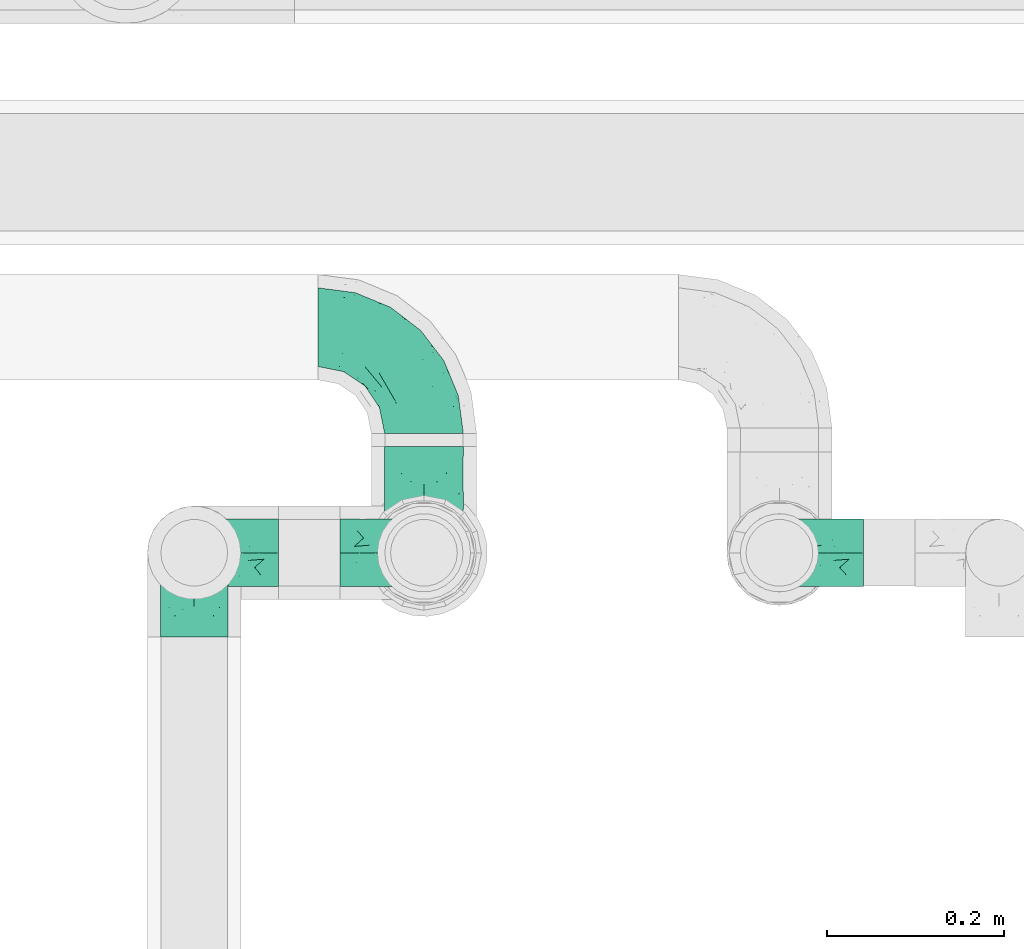
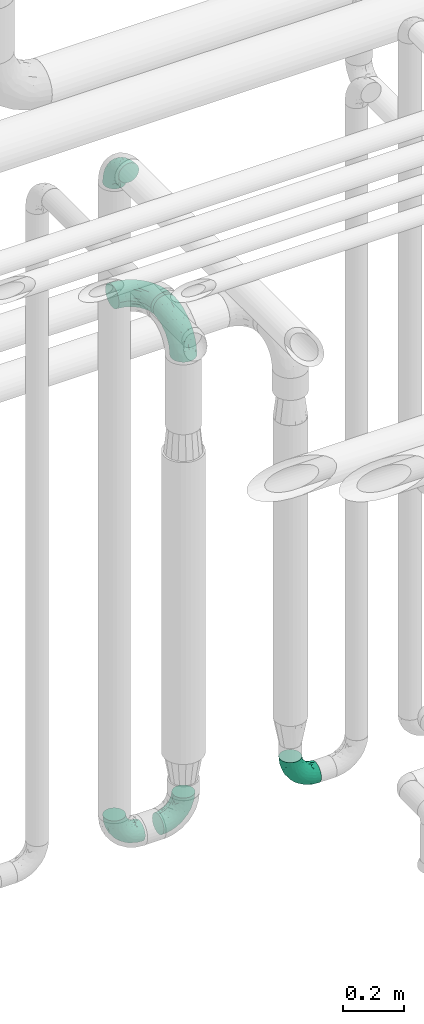
# One storey, part 711 of 827: 6 flow fittings.
"""IFC2X3 building model written with IfcOpenShell, lengths in millimetres."""

from ifc_helpers import new_model, entity, si_unit, converted_unit, derived_unit, direction, frame, origin, place, context, subcontext, project, spatial, faceted_brep, source, transform, mapped, material, type_object, type_shapes, element, save


model = new_model("IFC2X3")

# Units and contexts
model_context = context("Model", 3, precision=0.01, world=origin(), true_north=direction((6.12303176911189e-17, 1.0)))
body_context = subcontext(model_context, "Body", "Model", "MODEL_VIEW")
ifc_project = project(units=[si_unit("LENGTHUNIT", "METRE", prefix="MILLI"), si_unit("AREAUNIT", "SQUARE_METRE"), si_unit("VOLUMEUNIT", "CUBIC_METRE"), converted_unit("PLANEANGLEUNIT", "DEGREE", entity("IfcRatioMeasure", 0.0174532925199433), si_unit("PLANEANGLEUNIT", "RADIAN"), dimensions=[0, 0, 0, 0, 0, 0, 0]), si_unit("MASSUNIT", "GRAM", prefix="KILO"), derived_unit("MASSDENSITYUNIT", [(si_unit("MASSUNIT", "GRAM", prefix="KILO"), 1), (si_unit("LENGTHUNIT", "METRE"), -3)]), derived_unit("MOMENTOFINERTIAUNIT", [(si_unit("LENGTHUNIT", "METRE"), 4)]), si_unit("TIMEUNIT", "SECOND"), si_unit("FREQUENCYUNIT", "HERTZ"), si_unit("THERMODYNAMICTEMPERATUREUNIT", "DEGREE_CELSIUS"), derived_unit("THERMALTRANSMITTANCEUNIT", [(si_unit("MASSUNIT", "GRAM", prefix="KILO"), 1), (si_unit("THERMODYNAMICTEMPERATUREUNIT", "KELVIN"), -1), (si_unit("TIMEUNIT", "SECOND"), -3)]), derived_unit("VOLUMETRICFLOWRATEUNIT", [(si_unit("LENGTHUNIT", "METRE"), 3), (si_unit("TIMEUNIT", "SECOND"), -1)]), derived_unit("MASSFLOWRATEUNIT", [(si_unit("MASSUNIT", "GRAM", prefix="KILO"), 1), (si_unit("TIMEUNIT", "SECOND"), -1)]), derived_unit("ROTATIONALFREQUENCYUNIT", [(si_unit("TIMEUNIT", "SECOND"), -1)]), si_unit("ELECTRICCURRENTUNIT", "AMPERE"), si_unit("ELECTRICVOLTAGEUNIT", "VOLT"), si_unit("POWERUNIT", "WATT"), si_unit("FORCEUNIT", "NEWTON", prefix="KILO"), si_unit("ILLUMINANCEUNIT", "LUX"), si_unit("LUMINOUSFLUXUNIT", "LUMEN"), si_unit("LUMINOUSINTENSITYUNIT", "CANDELA"), derived_unit("USERDEFINED", [(si_unit("MASSUNIT", "GRAM", prefix="KILO"), -1), (si_unit("LENGTHUNIT", "METRE"), -2), (si_unit("TIMEUNIT", "SECOND"), 3), (si_unit("LUMINOUSFLUXUNIT", "LUMEN"), 1)]), derived_unit("LINEARVELOCITYUNIT", [(si_unit("LENGTHUNIT", "METRE"), 1), (si_unit("TIMEUNIT", "SECOND"), -1)]), si_unit("PRESSUREUNIT", "PASCAL"), derived_unit("USERDEFINED", [(si_unit("LENGTHUNIT", "METRE"), -2), (si_unit("MASSUNIT", "GRAM", prefix="KILO"), 1), (si_unit("TIMEUNIT", "SECOND"), -2)]), derived_unit("LINEARFORCEUNIT", [(si_unit("MASSUNIT", "GRAM", prefix="KILO"), 1), (si_unit("LENGTHUNIT", "METRE"), 1), (si_unit("TIMEUNIT", "SECOND"), -2), (si_unit("LENGTHUNIT", "METRE"), -1)]), derived_unit("PLANARFORCEUNIT", [(si_unit("MASSUNIT", "GRAM", prefix="KILO"), 1), (si_unit("LENGTHUNIT", "METRE"), 1), (si_unit("TIMEUNIT", "SECOND"), -2), (si_unit("LENGTHUNIT", "METRE"), -2)])], contexts=[model_context])

# Site, building, storey
site_placement = place(None, origin())
site = spatial("IfcSite", under=ifc_project, at=site_placement, CompositionType="ELEMENT")
building_placement = place(site_placement, origin())
building = spatial("IfcBuilding", under=site, at=building_placement, CompositionType="ELEMENT")
storey_placement = place(building_placement, frame((0.0, 0.0, 28200.0)))
storey = spatial("IfcBuildingStorey", under=building, at=storey_placement, Name="08", CompositionType="ELEMENT", Elevation=28200.0)

# Flow fittings
ifc_material = material()
pipe_fitting_type_1 = type_object("IfcPipeFittingType", Name="ADSK_2", PredefinedType="NOTDEFINED", material=ifc_material)
shared_shape_1 = source(origin(), body_context, "Body", "Brep", [
    faceted_brep([(-120.0, 22.25, -38.54), (-120.0, 11.52, -42.98), (-120.0, 0.0, -44.5), (-120.0, -11.52, -42.98), (-120.0, -22.25, -38.54), (-120.0, -31.47, -31.47), (-120.0, -38.54, -22.25), (-120.0, -42.98, -11.52), (-120.0, -44.5, 0.0), (-120.0, -42.98, 11.52), (-120.0, -38.54, 22.25), (-120.0, -31.47, 31.47), (-120.0, -22.25, 38.54), (-120.0, -11.52, 42.98), (-120.0, 0.0, 44.5), (-120.0, 11.52, 42.98), (-120.0, 22.25, 38.54), (-120.0, 31.47, 31.47), (-120.0, 38.54, 22.25), (-120.0, 42.98, 11.52), (-120.0, 44.5, 0.0), (-120.0, 42.98, -11.52), (-120.0, 38.54, -22.25), (-120.0, 31.47, -31.47), (0.0, 120.0, -44.5), (-11.52, 120.0, -42.98), (-22.25, 120.0, -38.54), (-31.47, 120.0, -31.47), (-38.54, 120.0, -22.25), (-42.98, 120.0, -11.52), (-44.5, 120.0, 0.0), (-42.98, 120.0, 11.52), (-38.54, 120.0, 22.25), (-31.47, 120.0, 31.47), (-22.25, 120.0, 38.54), (-11.52, 120.0, 42.98), (0.0, 120.0, 44.5), (11.52, 120.0, 42.98), (22.25, 120.0, 38.54), (31.47, 120.0, 31.47), (38.54, 120.0, 22.25), (42.98, 120.0, 11.52), (44.5, 120.0, 0.0), (42.98, 120.0, -11.52), (38.54, 120.0, -22.25), (31.47, 120.0, -31.47), (22.25, 120.0, -38.54), (11.52, 120.0, -42.98), (-20.51, 85.66, 41.98), (-29.31, 93.55, 36.45), (-98.0, -41.6, 0.0), (-80.92, -37.22, 14.68), (-66.68, -9.63, 39.67), (-84.59, -24.55, 33.9), (-50.35, -12.87, 32.85), (-77.42, -38.89, 0.0), (-22.01, -9.62, 13.21), (-37.75, -22.46, 0.0), (-20.72, -9.39, 0.0), (-89.18, -33.47, 25.4), (12.87, 50.35, 32.85), (24.55, 84.59, 33.9), (9.63, 66.68, 39.67), (-49.55, -27.06, 11.21), (-28.67, -9.99, 21.67), (-52.01, -22.41, 23.47), (-95.53, -16.28, 40.49), (-86.01, -3.42, 43.77), (22.41, 52.01, 23.47), (9.05, 21.37, 13.44), (26.5, 49.37, 12.73), (33.47, 89.18, 25.4), (37.22, 80.92, 14.68), (16.28, 95.53, 40.49), (3.42, 86.01, 43.77), (-7.84, 52.6, 43.16), (-84.39, 31.88, 36.84), (-30.52, 34.28, 44.33), (-21.99, 28.55, 42.22), (-93.56, 38.23, 28.63), (-65.04, 31.74, 41.51), (-91.98, 19.0, 41.83), (-34.03, 70.24, 39.41), (-96.36, 44.0, 18.64), (-98.49, 46.74, 8.65), (-76.5, 56.97, 9.76), (-4.96, 4.47, 11.32), (-7.16, 6.18, 18.93), (-56.62, 75.93, 12.18), (-66.61, 66.61, 0.0), (-92.12, 7.25, 44.33), (-7.23, 92.66, 44.32), (30.68, 57.59, 0.0), (-44.45, 94.8, 18.75), (-36.39, 101.98, 28.14), (-46.83, 97.45, 9.69), (-38.03, 47.61, 43.21), (-24.7, 65.7, 43.29), (41.6, 98.0, 0.0), (-54.11, 72.8, 21.53), (-47.95, 9.75, 42.93), (-18.65, 18.65, 37.89), (-91.11, 50.25, 0.0), (-50.25, 91.11, 0.0), (-57.59, -30.68, 0.0), (-44.16, 67.2, 34.92), (-55.15, 62.16, 29.74), (-68.1, 47.21, 32.31), (-51.09, 51.09, 38.36), (-16.69, 62.62, 44.46), (-58.26, 18.84, 44.48), (-71.55, 55.71, 20.49), (-43.13, 80.04, 29.45), (-37.23, 0.88, 36.78), (-18.15, 10.22, 33.09), (5.51, 28.08, 26.74), (-3.68, 3.68, 0.0), (9.39, 20.72, 0.0), (-2.58, 27.98, 33.59), (-2.38, 41.22, 38.93), (-16.09, 4.55, 27.06), (38.89, 77.42, 0.0), (22.46, 37.75, 0.0), (-92.66, 7.23, -44.32), (-22.01, -9.62, -13.21), (-49.81, -26.66, -12.91), (-28.67, -9.99, -21.67), (-62.62, 16.69, -44.46), (-65.04, 31.74, -41.51), (-38.89, 47.26, -43.11), (-56.62, 75.93, -12.18), (-93.56, 38.23, -28.63), (-84.39, 31.88, -36.84), (16.28, 95.53, -40.49), (3.42, 86.01, -43.77), (-98.49, 46.74, -8.65), (-44.45, 94.8, -18.75), (-54.11, 72.8, -21.53), (-76.5, 56.97, -9.76), (24.55, 84.59, -33.9), (9.63, 66.68, -39.67), (-96.36, 44.0, -18.64), (-29.4, 93.16, -36.47), (-91.98, 19.0, -41.83), (-80.92, -37.22, -14.68), (-52.6, 7.84, -43.16), (-86.01, -3.42, -43.77), (-89.18, -33.47, -25.4), (-52.01, -22.41, -23.47), (-50.35, -12.87, -32.85), (-84.59, -24.55, -33.9), (-66.68, -9.63, -39.67), (-95.53, -16.28, -40.49), (-68.1, 47.21, -32.31), (-35.81, 11.1, -40.85), (-19.61, 28.53, -41.59), (-18.65, 18.65, -37.89), (-4.97, 4.47, -11.34), (9.05, 21.37, -13.44), (-34.28, 30.52, -44.33), (-9.75, 47.95, -42.93), (-2.58, 27.98, -33.59), (-18.15, 10.22, -33.09), (-46.83, 97.45, -9.69), (12.87, 50.35, -32.85), (26.8, 49.13, -11.4), (-7.34, 92.03, -44.33), (-21.02, 83.86, -42.03), (-44.6, 66.82, -34.8), (-55.46, 62.18, -29.47), (37.22, 80.92, -14.68), (33.47, 89.18, -25.4), (-34.39, 70.11, -39.28), (-25.04, 64.41, -43.37), (-18.84, 58.26, -44.48), (22.41, 52.01, -23.47), (-36.39, 101.98, -28.14), (-51.09, 51.09, -38.36), (-43.13, 80.04, -29.45), (-71.55, 55.71, -20.49), (-7.15, 6.2, -18.94), (5.51, 28.08, -26.74), (-37.23, 0.88, -36.78), (-2.38, 41.22, -38.93), (-16.09, 4.55, -27.06)], [[[0, 1, 2, 3, 4, 5, 6, 7, 8, 9, 10, 11, 12, 13, 14, 15, 16, 17, 18, 19, 20, 21, 22, 23]], [[24, 25, 26, 27, 28, 29, 30, 31, 32, 33, 34, 35, 36, 37, 38, 39, 40, 41, 42, 43, 44, 45, 46, 47]], [[48, 34, 49]], [[50, 51, 9]], [[52, 53, 54]], [[9, 51, 10]], [[55, 51, 50]], [[56, 57, 58]], [[51, 59, 10]], [[60, 61, 62]], [[63, 64, 65]], [[13, 12, 66]], [[67, 14, 13]], [[68, 69, 70]], [[71, 68, 72]], [[38, 73, 61]], [[74, 75, 62]], [[17, 16, 76]], [[77, 78, 75]], [[79, 18, 17]], [[80, 76, 81]], [[35, 34, 48]], [[49, 82, 48]], [[18, 83, 19]], [[16, 81, 76]], [[20, 19, 84]], [[85, 84, 83]], [[56, 86, 87]], [[85, 88, 89]], [[37, 36, 74]], [[90, 14, 67]], [[79, 17, 76]], [[63, 65, 51]], [[13, 66, 67]], [[61, 39, 38]], [[91, 74, 36]], [[70, 92, 72]], [[93, 94, 32]], [[95, 88, 93]], [[62, 73, 74]], [[82, 96, 97]], [[40, 72, 41]], [[72, 68, 70]], [[71, 72, 40]], [[34, 33, 49]], [[72, 98, 41]], [[99, 93, 88]], [[71, 39, 61]], [[78, 100, 101]], [[85, 89, 102]], [[53, 52, 66]], [[103, 95, 30]], [[12, 11, 53]], [[103, 89, 88]], [[104, 57, 63]], [[91, 48, 97]], [[93, 32, 31]], [[33, 32, 94]], [[16, 15, 81]], [[105, 106, 107]], [[76, 107, 79]], [[35, 91, 36]], [[80, 96, 108]], [[31, 95, 93]], [[65, 53, 59]], [[73, 38, 37]], [[75, 74, 109]], [[61, 60, 68]], [[11, 10, 59]], [[54, 53, 65]], [[100, 67, 52]], [[110, 81, 90]], [[15, 14, 90]], [[76, 80, 108]], [[107, 76, 108]], [[83, 79, 111]], [[94, 49, 33]], [[82, 105, 108]], [[84, 85, 102]], [[111, 88, 85]], [[99, 88, 111]], [[94, 93, 112]], [[48, 91, 35]], [[74, 91, 109]], [[69, 87, 86]], [[113, 54, 114]], [[64, 56, 87]], [[60, 115, 68]], [[116, 117, 86]], [[69, 68, 115]], [[79, 83, 18]], [[85, 83, 111]], [[81, 110, 80]], [[110, 77, 96]], [[110, 96, 80]], [[97, 96, 109]], [[107, 108, 105]], [[111, 79, 107]], [[77, 75, 109]], [[118, 119, 101]], [[96, 77, 109]], [[77, 110, 100]], [[67, 100, 110]], [[100, 52, 113]], [[60, 119, 118]], [[118, 120, 115]], [[64, 54, 65]], [[114, 120, 118]], [[118, 115, 60]], [[115, 120, 87]], [[74, 73, 37]], [[61, 73, 62]], [[53, 66, 12]], [[67, 66, 52]], [[110, 90, 67]], [[15, 90, 81]], [[105, 49, 112]], [[96, 82, 108]], [[119, 60, 62]], [[118, 101, 114]], [[62, 75, 119]], [[78, 119, 75]], [[49, 105, 82]], [[105, 112, 106]], [[99, 112, 93]], [[111, 107, 106]], [[113, 114, 101]], [[54, 120, 114]], [[100, 113, 101]], [[52, 54, 113]], [[20, 84, 102]], [[83, 84, 19]], [[111, 106, 99]], [[112, 99, 106]], [[100, 78, 77]], [[119, 78, 101]], [[39, 71, 40]], [[68, 71, 61]], [[65, 59, 51]], [[11, 59, 53]], [[30, 95, 31]], [[103, 88, 95]], [[9, 8, 50]], [[98, 72, 121]], [[98, 42, 41]], [[49, 94, 112]], [[56, 63, 57]], [[51, 55, 104]], [[92, 121, 72]], [[86, 58, 116]], [[54, 64, 120]], [[115, 87, 69]], [[120, 64, 87]], [[58, 86, 56]], [[86, 117, 69]], [[91, 97, 109]], [[122, 69, 117]], [[82, 97, 48]], [[63, 56, 64]], [[104, 63, 51]], [[69, 122, 70]], [[92, 70, 122]], [[123, 2, 1]], [[124, 125, 126]], [[127, 128, 129]], [[103, 130, 89]], [[23, 131, 132]], [[47, 133, 134]], [[102, 135, 20]], [[130, 136, 137]], [[102, 138, 135]], [[139, 140, 133]], [[22, 21, 141]], [[27, 26, 142]], [[46, 45, 139]], [[0, 143, 1]], [[6, 144, 7]], [[145, 146, 127]], [[144, 50, 7]], [[147, 148, 144]], [[144, 6, 147]], [[149, 150, 151]], [[4, 3, 152]], [[23, 22, 131]], [[132, 131, 153]], [[43, 42, 98]], [[125, 104, 144]], [[154, 155, 156]], [[146, 151, 152]], [[4, 150, 5]], [[123, 146, 2]], [[157, 158, 117]], [[130, 138, 89]], [[29, 28, 136]], [[159, 160, 155]], [[161, 162, 156]], [[89, 138, 102]], [[163, 30, 29]], [[164, 140, 139]], [[163, 136, 130]], [[23, 132, 0]], [[158, 165, 122]], [[25, 24, 166]], [[0, 132, 143]], [[4, 152, 150]], [[142, 26, 167]], [[3, 2, 146]], [[167, 26, 25]], [[133, 47, 46]], [[168, 153, 169]], [[146, 145, 151]], [[149, 126, 148]], [[44, 170, 171]], [[24, 47, 134]], [[170, 44, 43]], [[144, 148, 125]], [[170, 98, 121]], [[168, 142, 172]], [[129, 173, 174]], [[98, 170, 43]], [[147, 5, 150]], [[157, 58, 124]], [[92, 122, 165]], [[134, 166, 24]], [[175, 139, 171]], [[28, 27, 176]], [[29, 136, 163]], [[132, 128, 143]], [[45, 44, 171]], [[164, 139, 175]], [[160, 134, 140]], [[174, 173, 166]], [[141, 131, 22]], [[132, 153, 177]], [[128, 132, 177]], [[123, 143, 127]], [[172, 142, 167]], [[176, 142, 178]], [[130, 179, 138]], [[138, 179, 141]], [[176, 136, 28]], [[130, 137, 179]], [[174, 166, 134]], [[167, 25, 166]], [[143, 123, 1]], [[146, 123, 127]], [[150, 149, 148]], [[157, 124, 180]], [[181, 161, 164]], [[181, 158, 180]], [[124, 126, 180]], [[170, 165, 175]], [[141, 21, 135]], [[131, 141, 179]], [[131, 179, 153]], [[179, 137, 169]], [[129, 128, 177]], [[127, 143, 128]], [[129, 177, 172]], [[129, 174, 159]], [[159, 145, 127]], [[182, 154, 156]], [[129, 159, 127]], [[159, 174, 160]], [[134, 160, 174]], [[140, 164, 183]], [[162, 182, 156]], [[126, 149, 184]], [[181, 164, 175]], [[164, 161, 183]], [[158, 181, 175]], [[184, 162, 161]], [[146, 152, 3]], [[150, 152, 151]], [[139, 133, 46]], [[134, 133, 140]], [[184, 161, 181]], [[161, 156, 183]], [[155, 183, 156]], [[160, 140, 183]], [[184, 149, 162]], [[182, 162, 149]], [[149, 151, 182]], [[154, 151, 145]], [[151, 154, 182]], [[159, 154, 145]], [[159, 155, 154]], [[183, 155, 160]], [[141, 135, 138]], [[20, 135, 21]], [[136, 178, 137]], [[169, 178, 168]], [[172, 167, 173]], [[168, 172, 177]], [[153, 168, 177]], [[142, 168, 178]], [[179, 169, 153]], [[137, 178, 169]], [[5, 147, 6]], [[148, 147, 150]], [[175, 171, 170]], [[45, 171, 139]], [[130, 103, 163]], [[30, 163, 103]], [[50, 144, 55]], [[50, 8, 7]], [[142, 176, 27]], [[136, 176, 178]], [[126, 125, 148]], [[104, 55, 144]], [[170, 121, 92]], [[58, 57, 124]], [[180, 126, 184]], [[181, 180, 184]], [[180, 158, 157]], [[158, 122, 117]], [[58, 157, 116]], [[172, 173, 129]], [[116, 157, 117]], [[166, 173, 167]], [[124, 57, 125]], [[104, 125, 57]], [[175, 165, 158]], [[92, 165, 170]]]),
])
type_shapes(pipe_fitting_type_1, [shared_shape_1])
for number, where, z_axis, x_axis, name in (
    (1, (58247.57, 17500.0, 2300.0), (1.0, 0.0, 0.0), (0.0, -1.0, 0.0), "ADSK_2"),
    (2, (58247.57, 17755.1, 2300.0), (0.0, 0.0, 1.0), (0.0, 1.0, 0.0), "ADSK_2"),
):
    element("IfcFlowFitting", number, at=place(storey_placement, frame(where, z_axis=z_axis, x_axis=x_axis)), inside=storey, type_object=pipe_fitting_type_1, material=ifc_material, Name=name, ObjectType="ADSK_2", context=body_context, shape_type="MappedRepresentation", body=[
        mapped(shared_shape_1, transform((0.0, 0.0, 0.0), scale=1.0)),
    ])
pipe_fitting_type_2 = type_object("IfcPipeFittingType", Name="ADSK_1", PredefinedType="NOTDEFINED", material=ifc_material)
shared_shape_2 = source(origin(), body_context, "Body", "Brep", [
    faceted_brep([(-95.0, 19.02, -32.95), (-95.0, 9.85, -36.75), (-95.0, 0.0, -38.05), (-95.0, -9.85, -36.75), (-95.0, -19.03, -32.95), (-95.0, -26.91, -26.91), (-95.0, -32.95, -19.03), (-95.0, -36.75, -9.85), (-95.0, -38.05, 0.0), (-95.0, -36.75, 9.85), (-95.0, -32.95, 19.02), (-95.0, -26.91, 26.91), (-95.0, -19.03, 32.95), (-95.0, -9.85, 36.75), (-95.0, 0.0, 38.05), (-95.0, 9.85, 36.75), (-95.0, 19.02, 32.95), (-95.0, 26.91, 26.91), (-95.0, 32.95, 19.02), (-95.0, 36.75, 9.85), (-95.0, 38.05, 0.0), (-95.0, 36.75, -9.85), (-95.0, 32.95, -19.03), (-95.0, 26.91, -26.91), (0.0, 95.0, -38.05), (-9.85, 95.0, -36.75), (-19.02, 95.0, -32.95), (-26.91, 95.0, -26.91), (-32.95, 95.0, -19.03), (-36.75, 95.0, -9.85), (-38.05, 95.0, 0.0), (-36.75, 95.0, 9.85), (-32.95, 95.0, 19.02), (-26.91, 95.0, 26.91), (-19.02, 95.0, 32.95), (-9.85, 95.0, 36.75), (0.0, 95.0, 38.05), (9.85, 95.0, 36.75), (19.03, 95.0, 32.95), (26.91, 95.0, 26.91), (32.95, 95.0, 19.02), (36.75, 95.0, 9.85), (38.05, 95.0, 0.0), (36.75, 95.0, -9.85), (32.95, 95.0, -19.03), (26.91, 95.0, -26.91), (19.03, 95.0, -32.95), (9.85, 95.0, -36.75), (-7.99, -4.96, 6.3), (-0.92, 0.92, 0.0), (4.62, 8.1, 8.01), (-76.19, -35.57, 0.0), (-64.32, -32.32, 12.43), (20.51, 62.45, 28.68), (-60.56, -33.52, 0.0), (-70.4, -13.47, 34.42), (-39.61, -5.88, 32.32), (-49.6, 2.07, 37.1), (-70.34, -28.81, 21.71), (14.64, 40.81, 26.5), (5.88, 39.61, 32.32), (3.59, 20.77, 25.31), (-40.45, 68.06, 16.75), (-62.45, -20.51, 28.68), (-44.52, -26.87, 0.0), (-28.47, -20.22, 0.0), (-26.43, -17.83, 8.75), (-76.1, 39.63, 10.76), (-72.74, 37.58, 18.19), (-60.35, 46.18, 14.61), (-13.4, 13.4, 32.12), (-20.77, -3.59, 25.31), (-14.66, 81.47, 35.56), (-6.22, 71.26, 37.92), (-57.5, 42.48, 22.79), (-15.0, 34.74, 37.7), (-27.1, 12.08, 36.05), (-9.2, 28.81, 35.63), (-79.98, 23.7, 30.95), (-73.68, -4.3, 37.48), (-30.74, 21.67, 37.97), (-62.36, 47.59, 6.79), (-72.71, 32.83, 24.69), (-67.42, 7.02, 37.95), (-32.13, 75.27, 24.51), (-43.46, 51.47, 26.26), (-24.98, 73.15, 31.29), (20.59, 41.28, 19.85), (7.79, 16.09, 15.86), (-73.21, 42.39, 0.0), (-54.73, 54.73, 0.0), (-73.44, 15.79, 35.79), (-5.94, 4.32, 20.43), (28.81, 70.34, 21.71), (32.32, 64.32, 12.43), (-53.59, 26.2, 35.09), (-52.02, 19.31, 37.21), (21.38, 33.53, 10.34), (26.87, 44.52, 0.0), (-48.28, 12.14, 38.05), (4.3, 73.68, 37.48), (-44.08, -25.52, 12.79), (-41.28, -20.59, 19.85), (35.57, 76.19, 0.0), (-47.26, 54.3, 20.18), (-47.4, 61.99, 8.58), (-42.39, 73.21, 0.0), (-39.67, 78.86, 7.21), (-45.69, 36.84, 33.11), (-32.83, 50.13, 33.35), (13.47, 70.4, 34.42), (-18.25, 63.73, 36.07), (-40.63, -13.75, 27.22), (-16.63, 46.37, 37.95), (-53.47, 38.79, 28.59), (-26.07, 48.54, 36.15), (-34.51, 34.51, 36.86), (-2.07, 49.6, 37.1), (-22.79, -10.49, 19.23), (-61.73, 28.67, 31.87), (9.65, 14.7, 0.0), (20.22, 28.47, 0.0), (33.52, 60.56, 0.0), (-11.42, -5.44, 13.25), (-14.7, -9.65, 0.0), (-81.47, 14.66, -35.56), (-62.45, -20.51, -28.68), (-71.26, 6.22, -37.92), (-75.27, 32.13, -24.51), (-73.15, 24.98, -31.29), (13.47, 70.4, -34.42), (5.88, 39.61, -32.32), (-2.07, 49.6, -37.1), (-78.86, 39.67, -7.21), (-70.4, -13.47, -34.42), (-39.61, -5.88, -32.32), (-61.99, 47.4, -8.58), (32.32, 64.32, -12.43), (28.81, 70.34, -21.71), (-63.73, 18.25, -36.07), (-50.13, 32.83, -33.35), (4.3, 73.68, -37.48), (-7.02, 67.42, -37.95), (-39.63, 76.1, -10.76), (-46.18, 60.35, -14.61), (-47.59, 62.36, -6.79), (-64.32, -32.32, -12.43), (-26.2, 53.59, -35.09), (-15.79, 73.44, -35.79), (-19.31, 52.02, -37.21), (-37.58, 72.74, -18.19), (-70.34, -28.81, -21.71), (-42.48, 57.5, -22.79), (-38.79, 53.47, -28.59), (-51.47, 43.46, -26.26), (-32.83, 72.71, -24.69), (-46.37, 16.63, -37.95), (-73.68, -4.3, -37.48), (-41.28, -20.59, -19.85), (-44.08, -25.52, -12.79), (13.75, 40.63, -27.22), (20.51, 62.45, -28.68), (-68.06, 40.45, -16.75), (-54.3, 47.26, -20.18), (-12.14, 48.28, -38.05), (-21.67, 30.74, -37.97), (-36.84, 45.69, -33.11), (-11.42, -5.44, -13.25), (7.79, 16.09, -15.86), (4.62, 8.1, -8.01), (-23.7, 79.98, -30.95), (-26.43, -17.83, -8.75), (-7.99, -4.96, -6.3), (-40.81, -14.64, -26.5), (-20.77, -3.59, -25.31), (-34.74, 15.0, -37.7), (-12.08, 27.1, -36.05), (-28.81, 9.2, -35.63), (-22.79, -10.49, -19.23), (21.38, 33.53, -10.34), (20.59, 41.28, -19.85), (-48.54, 26.07, -36.15), (-49.6, 2.07, -37.1), (-13.4, 13.4, -32.12), (3.59, 20.77, -25.31), (-28.67, 61.73, -31.87), (-34.51, 34.51, -36.86), (-5.94, 4.32, -20.43)], [[[0, 1, 2, 3, 4, 5, 6, 7, 8, 9, 10, 11, 12, 13, 14, 15, 16, 17, 18, 19, 20, 21, 22, 23]], [[24, 25, 26, 27, 28, 29, 30, 31, 32, 33, 34, 35, 36, 37, 38, 39, 40, 41, 42, 43, 44, 45, 46, 47]], [[48, 49, 50]], [[51, 52, 9]], [[53, 39, 38]], [[9, 52, 10]], [[54, 52, 51]], [[55, 56, 57]], [[11, 10, 58]], [[59, 60, 61]], [[32, 31, 62]], [[63, 12, 11]], [[63, 55, 12]], [[64, 65, 66]], [[67, 68, 69]], [[70, 56, 71]], [[35, 72, 73]], [[69, 68, 74]], [[75, 76, 77]], [[16, 78, 17]], [[13, 79, 14]], [[76, 75, 80]], [[67, 69, 81]], [[18, 17, 82]], [[14, 79, 83]], [[20, 19, 67]], [[84, 85, 86]], [[87, 61, 88]], [[89, 81, 90]], [[18, 82, 68]], [[15, 91, 16]], [[14, 83, 15]], [[71, 92, 61]], [[17, 78, 82]], [[93, 87, 94]], [[95, 91, 96]], [[97, 98, 94]], [[86, 72, 34]], [[96, 99, 80]], [[37, 36, 100]], [[40, 39, 93]], [[40, 94, 41]], [[64, 66, 101]], [[93, 94, 40]], [[58, 102, 63]], [[94, 103, 41]], [[94, 87, 97]], [[104, 69, 74]], [[34, 33, 86]], [[105, 69, 104]], [[52, 58, 10]], [[106, 107, 30]], [[108, 109, 85]], [[105, 106, 90]], [[53, 110, 60]], [[86, 111, 72]], [[86, 109, 111]], [[33, 84, 86]], [[12, 55, 13]], [[112, 56, 63]], [[110, 38, 37]], [[34, 72, 35]], [[36, 35, 73]], [[111, 113, 73]], [[105, 107, 106]], [[110, 53, 38]], [[74, 114, 85]], [[91, 15, 83]], [[105, 90, 81]], [[107, 62, 31]], [[33, 32, 84]], [[115, 109, 116]], [[111, 115, 113]], [[100, 73, 117]], [[56, 55, 63]], [[79, 55, 57]], [[102, 118, 112]], [[56, 70, 76]], [[100, 110, 37]], [[117, 77, 60]], [[117, 60, 110]], [[60, 70, 61]], [[58, 52, 101]], [[63, 11, 58]], [[39, 53, 93]], [[87, 93, 53]], [[96, 91, 83]], [[78, 91, 119]], [[32, 62, 84]], [[84, 62, 104]], [[86, 85, 109]], [[85, 114, 108]], [[80, 113, 116]], [[117, 73, 113]], [[80, 116, 96]], [[80, 57, 76]], [[71, 112, 118]], [[61, 87, 59]], [[62, 107, 105]], [[97, 120, 121]], [[70, 71, 61]], [[71, 118, 92]], [[73, 100, 36]], [[110, 100, 117]], [[55, 79, 13]], [[83, 79, 57]], [[96, 83, 99]], [[116, 108, 95]], [[50, 97, 88]], [[97, 87, 88]], [[50, 49, 120]], [[122, 94, 98]], [[89, 20, 67]], [[105, 81, 69]], [[89, 67, 81]], [[68, 19, 18]], [[68, 67, 19]], [[74, 68, 82]], [[114, 82, 119]], [[74, 85, 104]], [[82, 114, 74]], [[114, 119, 108]], [[95, 108, 119]], [[116, 109, 108]], [[123, 48, 50]], [[97, 50, 120]], [[123, 50, 88]], [[91, 95, 119]], [[116, 95, 96]], [[84, 104, 85]], [[104, 62, 105]], [[83, 57, 99]], [[57, 80, 99]], [[66, 48, 123]], [[66, 124, 48]], [[118, 66, 123]], [[124, 66, 65]], [[66, 118, 101]], [[54, 64, 52]], [[124, 49, 48]], [[30, 107, 31]], [[91, 78, 16]], [[82, 78, 119]], [[56, 76, 57]], [[77, 76, 70]], [[60, 77, 70]], [[77, 117, 75]], [[117, 113, 75]], [[113, 80, 75]], [[9, 8, 51]], [[103, 94, 122]], [[103, 42, 41]], [[73, 72, 111]], [[113, 115, 116]], [[111, 109, 115]], [[102, 112, 63]], [[71, 56, 112]], [[118, 102, 101]], [[92, 123, 88]], [[123, 92, 118]], [[61, 92, 88]], [[87, 53, 59]], [[60, 59, 53]], [[97, 121, 98]], [[58, 101, 102]], [[64, 101, 52]], [[125, 1, 0]], [[126, 5, 4]], [[2, 1, 127]], [[1, 125, 127]], [[128, 129, 23]], [[130, 131, 132]], [[89, 133, 20]], [[126, 134, 135]], [[136, 89, 90]], [[137, 138, 44]], [[139, 129, 140]], [[24, 141, 142]], [[143, 144, 145]], [[125, 129, 139]], [[6, 146, 7]], [[147, 148, 149]], [[146, 51, 7]], [[143, 150, 144]], [[146, 6, 151]], [[152, 153, 154]], [[126, 4, 134]], [[0, 23, 129]], [[28, 155, 150]], [[43, 42, 103]], [[54, 146, 64]], [[139, 156, 127]], [[157, 3, 2]], [[151, 158, 159]], [[160, 131, 161]], [[22, 21, 162]], [[136, 144, 163]], [[149, 164, 165]], [[24, 142, 25]], [[166, 140, 154]], [[154, 129, 128]], [[143, 30, 29]], [[167, 168, 169]], [[155, 28, 27]], [[26, 170, 27]], [[171, 167, 172]], [[26, 25, 148]], [[27, 170, 155]], [[173, 135, 174]], [[144, 150, 152]], [[175, 176, 177]], [[24, 47, 141]], [[45, 161, 46]], [[148, 25, 142]], [[176, 175, 165]], [[64, 159, 171]], [[138, 45, 44]], [[130, 46, 161]], [[137, 44, 43]], [[178, 159, 158]], [[137, 103, 122]], [[163, 144, 152]], [[136, 133, 89]], [[103, 137, 43]], [[6, 5, 151]], [[178, 158, 173]], [[134, 4, 3]], [[178, 173, 174]], [[137, 98, 179]], [[145, 90, 106]], [[138, 180, 161]], [[46, 130, 47]], [[136, 90, 145]], [[133, 162, 21]], [[23, 22, 128]], [[139, 140, 181]], [[139, 181, 156]], [[157, 127, 182]], [[157, 134, 3]], [[182, 177, 135]], [[182, 135, 134]], [[135, 183, 174]], [[131, 130, 161]], [[141, 130, 132]], [[160, 180, 184]], [[131, 183, 176]], [[5, 126, 151]], [[158, 151, 126]], [[180, 138, 137]], [[161, 45, 138]], [[149, 148, 142]], [[170, 148, 185]], [[22, 162, 128]], [[128, 162, 163]], [[129, 154, 140]], [[154, 153, 166]], [[165, 156, 186]], [[182, 127, 156]], [[165, 186, 149]], [[165, 132, 176]], [[131, 184, 183]], [[187, 167, 178]], [[184, 168, 187]], [[167, 169, 172]], [[184, 180, 168]], [[174, 183, 184]], [[127, 157, 2]], [[134, 157, 182]], [[130, 141, 47]], [[142, 141, 132]], [[149, 142, 164]], [[186, 166, 147]], [[180, 179, 168]], [[169, 179, 120]], [[137, 179, 180]], [[179, 121, 120]], [[106, 30, 143]], [[136, 145, 144]], [[106, 143, 145]], [[150, 29, 28]], [[150, 143, 29]], [[152, 150, 155]], [[153, 155, 185]], [[152, 154, 163]], [[155, 153, 152]], [[153, 185, 166]], [[147, 166, 185]], [[186, 140, 166]], [[169, 120, 49]], [[169, 49, 172]], [[179, 169, 168]], [[148, 147, 185]], [[186, 147, 149]], [[128, 163, 154]], [[163, 162, 136]], [[142, 132, 164]], [[132, 165, 164]], [[171, 124, 65]], [[124, 171, 172]], [[64, 146, 159]], [[171, 159, 178]], [[171, 65, 64]], [[172, 49, 124]], [[162, 133, 136]], [[20, 133, 21]], [[148, 170, 26]], [[155, 170, 185]], [[131, 176, 132]], [[177, 176, 183]], [[135, 177, 183]], [[177, 182, 175]], [[182, 156, 175]], [[156, 165, 175]], [[51, 146, 54]], [[51, 8, 7]], [[129, 125, 0]], [[127, 125, 139]], [[140, 186, 181]], [[156, 181, 186]], [[158, 126, 173]], [[135, 173, 126]], [[187, 178, 174]], [[171, 178, 167]], [[184, 187, 174]], [[167, 187, 168]], [[180, 160, 161]], [[184, 131, 160]], [[98, 137, 122]], [[98, 121, 179]], [[151, 159, 146]]]),
])
type_shapes(pipe_fitting_type_2, [shared_shape_2])
for number, where, z_axis, x_axis, name in (
    (3, (57987.89, 17500.0, 350.0), (0.0, -1.0, 0.0), (0.0, 0.0, -1.0), "ADSK_1"),
    (4, (58247.57, 17500.0, 350.0), (0.0, -1.0, 0.0), (1.0, 0.0, 0.0), "ADSK_1"),
    (5, (58649.38, 17500.0, 350.0), (0.0, 1.0, 0.0), (-1.0, 0.0, 0.0), "ADSK_1"),
    (6, (57987.89, 17500.0, 3050.0), (1.0, 0.0, 0.0), (0.0, 0.0, 1.0), "ADSK_1"),
):
    element("IfcFlowFitting", number, at=place(storey_placement, frame(where, z_axis=z_axis, x_axis=x_axis)), inside=storey, type_object=pipe_fitting_type_2, material=ifc_material, Name=name, ObjectType="ADSK_1", context=body_context, shape_type="MappedRepresentation", body=[
        mapped(shared_shape_2, transform((0.0, 0.0, 0.0), scale=1.0)),
    ])

save(model, "model.ifc")
